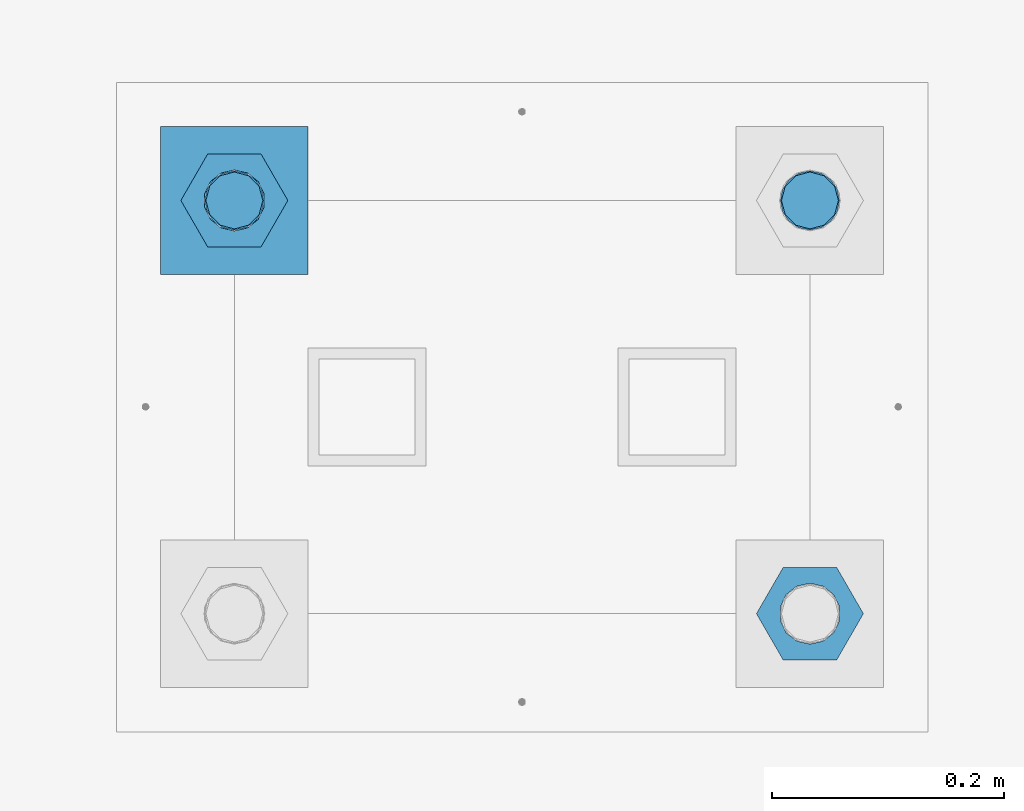
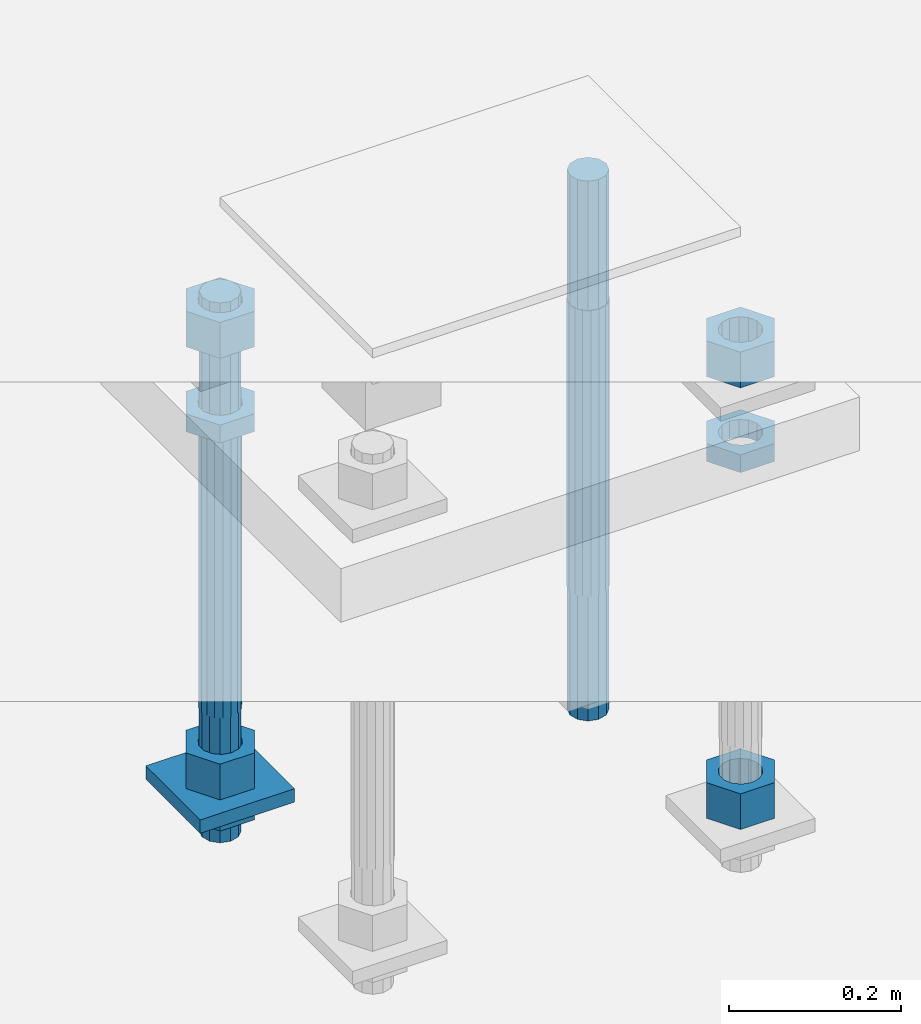
# One storey, part 2574 of 3843: 10 beams, 1 element without a shape of its own.
"""IFC2X3 building model written with IfcOpenShell, lengths in millimetres."""

import ifcopenshell
import ifcopenshell.guid

model = None  # the IFC model being written
_history = None  # IfcOwnerHistory: only IFC2X3 demands one
_inside = {}  # id of a spatial element -> (the spatial element, [elements in it])
_under = {}  # id of a project, library or spatial element -> (it, [spatial elements below it])
_declared = {}  # id of a project -> (the project, [libraries it declares])
_typed = {}  # id of a type object -> (the type object, [elements of that type])
_made_of = {}  # id of a material, layer set ... -> (it, [elements and type objects made of it])


def new_model(schema):
    """Start an empty IFC model of exactly this schema.

    Asked for "IFC4X3", IfcOpenShell would pick the latest addendum, in which some entities
    have other attributes; the version numbers below select the first issue.
    IFC2X3 requires an IfcOwnerHistory on every rooted entity: one is made here for all.
    """
    global model, _history
    if schema == "IFC4X3":
        model = ifcopenshell.file(schema_version=(4, 3, 0, 0))
    else:
        model = ifcopenshell.file(schema=schema)
    _inside.clear()
    _under.clear()
    _declared.clear()
    _typed.clear()
    _made_of.clear()
    _history = None
    if model.schema == "IFC2X3":
        org = make("IfcOrganization", Name="unknown")
        user = make(
            "IfcPersonAndOrganization",
            ThePerson=make("IfcPerson", FamilyName="unknown"),
            TheOrganization=org,
        )
        app = make(
            "IfcApplication",
            ApplicationDeveloper=org,
            Version="unknown",
            ApplicationFullName="unknown",
            ApplicationIdentifier="unknown",
        )
        _history = make(
            "IfcOwnerHistory",
            OwningUser=user,
            OwningApplication=app,
            ChangeAction="ADDED",
            CreationDate=0,
        )
    return model


def make(cls, **values):
    """One entity of the class cls with the attributes given. An attribute that is None is left unset."""
    return model.create_entity(
        cls, **{name: value for name, value in values.items() if value is not None}
    )


def rooted(cls, **values):
    """An entity with a GlobalId (a new one), such as an element, a storey or a relation."""
    return make(cls, GlobalId=ifcopenshell.guid.new(), OwnerHistory=_history, **values)


def si_unit(unit_type, name, prefix=None):
    """IfcSIUnit, for example si_unit("LENGTHUNIT", "METRE", prefix="MILLI")."""
    return make("IfcSIUnit", UnitType=unit_type, Prefix=prefix, Name=name)


def assignment(units):
    """IfcUnitAssignment: the units of a project."""
    return None if units is None else make("IfcUnitAssignment", Units=units)


def point(xyz):
    """IfcCartesianPoint."""
    return None if xyz is None else make("IfcCartesianPoint", Coordinates=xyz)


def direction(xyz):
    """IfcDirection."""
    return None if xyz is None else make("IfcDirection", DirectionRatios=xyz)


def frame(location, z_axis=None, x_axis=None):
    """IfcAxis2Placement3D, a coordinate frame: its origin and axes. An axis left out is left unset."""
    return make(
        "IfcAxis2Placement3D",
        Location=point(location),
        Axis=direction(z_axis),
        RefDirection=direction(x_axis),
    )


def origin_with_axes():
    """The frame at (0, 0, 0) with the z axis (0, 0, 1) and the x axis (1, 0, 0) written out."""
    return frame((0.0, 0.0, 0.0), z_axis=(0.0, 0.0, 1.0), x_axis=(1.0, 0.0, 0.0))


def place(relative_to, where):
    """IfcLocalPlacement: puts the frame where relative to a parent placement (None: the world)."""
    return make(
        "IfcLocalPlacement", PlacementRelTo=relative_to, RelativePlacement=where
    )


def context(
    kind, dimensions, precision=None, world=None, true_north=None, identifier=None
):
    """IfcGeometricRepresentationContext, for example the 3D "Model" context."""
    return make(
        "IfcGeometricRepresentationContext",
        ContextIdentifier=identifier,
        ContextType=kind,
        CoordinateSpaceDimension=dimensions,
        Precision=precision,
        WorldCoordinateSystem=world,
        TrueNorth=true_north,
    )


def subcontext(parent, identifier, kind, view, scale=None):
    """IfcGeometricRepresentationSubContext, for example "Body" below "Model"."""
    return make(
        "IfcGeometricRepresentationSubContext",
        ContextIdentifier=identifier,
        ContextType=kind,
        ParentContext=parent,
        TargetScale=scale,
        TargetView=view,
    )


def project(units=None, contexts=None):
    """IfcProject with its units and contexts."""
    return rooted(
        "IfcProject",
        Name="project",
        RepresentationContexts=contexts,
        UnitsInContext=assignment(units),
    )


def spatial(cls, under=None, at=None, **own):
    """A site, building, storey or space (cls), placed at a placement, below another one or the project."""
    s = rooted(cls, ObjectPlacement=at, **own)
    if under is not None:
        _under.setdefault(under.id(), (under, []))[1].append(s)
    return s


def faces_of(points, faces, orient=None, outer=None):
    """IfcFace entities. A face is a list of loops; a loop is a list of indices into points, from 0.

    orient and outer hold one flag for each loop. By default every Orientation is true, the
    first loop of a face is its IfcFaceOuterBound and the others are IfcFaceBound.
    """
    made = []
    for i, loops in enumerate(faces):
        bounds = []
        for j, loop in enumerate(loops):
            is_outer = j == 0 if outer is None else outer[i][j]
            bounds.append(
                make(
                    "IfcFaceOuterBound" if is_outer else "IfcFaceBound",
                    Bound=make("IfcPolyLoop", Polygon=[points[k] for k in loop]),
                    Orientation=True if orient is None else orient[i][j],
                )
            )
        made.append(make("IfcFace", Bounds=bounds))
    return made


def faceted_brep(points, faces, orient=None, outer=None, voids=None):
    """IfcFacetedBrep: a solid bounded by flat faces; with voids (closed shells), ...WithVoids."""
    shared = [point(p) for p in points]
    hull = make("IfcClosedShell", CfsFaces=faces_of(shared, faces, orient, outer))
    if voids is None:
        return make("IfcFacetedBrep", Outer=hull)
    return make(
        "IfcFacetedBrepWithVoids",
        Outer=hull,
        Voids=[
            make(cls, CfsFaces=faces_of(shared, fs, o, b)) for cls, fs, o, b in voids
        ],
    )


def shape(context_of_items, identifier, shape_type, items):
    """IfcShapeRepresentation: the items that make up one representation, for example the "Body"."""
    return make(
        "IfcShapeRepresentation",
        ContextOfItems=context_of_items,
        RepresentationIdentifier=identifier,
        RepresentationType=shape_type,
        Items=items,
    )


def material(Name=None, Category=None):
    """IfcMaterial."""
    return make("IfcMaterial", Name=Name, Category=Category)


def made_of(thing, what):
    """Note that an element or type object is made of a material, layer set ...; save() writes the relation."""
    if what is not None:
        _made_of.setdefault(what.id(), (what, []))[1].append(thing)
    return thing


def type_object(cls, material=None, **own):
    """A type object (cls), such as IfcWallType, which elements share."""
    return made_of(rooted(cls, **own), material)


def element(
    cls,
    number,
    at=None,
    inside=None,
    cuts=None,
    type_object=None,
    material=None,
    context=None,
    identifier="Body",
    shape_type=None,
    held_by="IfcProductDefinitionShape",
    body=None,
    shapes=None,
    **own,
):
    """One element of the class cls, such as IfcWall. Its Tag is "e" and its number.

    at: its placement. inside: the storey or other place that contains it. cuts: it is an
    opening in that element (IfcRelVoidsElement). A single representation is given by context,
    identifier, shape_type and body (its items); several are given by shapes. held_by: the class
    of the entity that holds the representations. save() writes the other relations.
    """
    e = rooted(cls, Tag="e%d" % number, ObjectPlacement=at, **own)
    if body is not None:
        shapes = [shape(context, identifier, shape_type, body)]
    if shapes is not None:
        e.Representation = make(held_by, Representations=shapes)
    if inside is not None:
        _inside.setdefault(inside.id(), (inside, []))[1].append(e)
    if cuts is not None:
        rooted(
            "IfcRelVoidsElement", RelatingBuildingElement=cuts, RelatedOpeningElement=e
        )
    if type_object is not None:
        _typed.setdefault(type_object.id(), (type_object, []))[1].append(e)
    return made_of(e, material)


def aggregate(whole, parts):
    """IfcRelAggregates: a whole, such as a stair, and the parts it consists of."""
    return rooted("IfcRelAggregates", RelatingObject=whole, RelatedObjects=parts)


def save(model, path):
    """Write the relations noted so far, then the file.

    IfcRelAggregates (storeys below a building ...), IfcRelContainedInSpatialStructure (elements
    in a storey), IfcRelDefinesByType, IfcRelAssociatesMaterial and IfcRelDeclares: one each for
    every whole, place, type object, material and project.
    """
    for whole, parts in _under.values():
        aggregate(whole, parts)
    for where, things in _inside.values():
        rooted(
            "IfcRelContainedInSpatialStructure",
            RelatedElements=things,
            RelatingStructure=where,
        )
    for kind, things in _typed.values():
        rooted("IfcRelDefinesByType", RelatedObjects=things, RelatingType=kind)
    for what, things in _made_of.values():
        rooted("IfcRelAssociatesMaterial", RelatedObjects=things, RelatingMaterial=what)
    for by, libraries in _declared.values():
        rooted("IfcRelDeclares", RelatingContext=by, RelatedDefinitions=libraries)
    model.write(path)


model = new_model("IFC2X3")

# Units and contexts
model_context = context("Model", 3, precision=1e-05, world=origin_with_axes())
body_context = subcontext(model_context, "Body", "Model", "MODEL_VIEW")
ifc_project = project(units=[si_unit("LENGTHUNIT", "METRE", prefix="MILLI"), si_unit("AREAUNIT", "SQUARE_METRE"), si_unit("VOLUMEUNIT", "CUBIC_METRE"), si_unit("MASSUNIT", "GRAM", prefix="KILO"), si_unit("TIMEUNIT", "SECOND"), si_unit("PLANEANGLEUNIT", "RADIAN"), si_unit("SOLIDANGLEUNIT", "STERADIAN"), si_unit("THERMODYNAMICTEMPERATUREUNIT", "DEGREE_CELSIUS"), si_unit("LUMINOUSINTENSITYUNIT", "LUMEN")], contexts=[model_context])

# Site, building, storey
site_placement = place(None, origin_with_axes())
site = spatial("IfcSite", under=ifc_project, at=site_placement, CompositionType="ELEMENT")
building_placement = place(site_placement, origin_with_axes())
building = spatial("IfcBuilding", under=site, at=building_placement, Name="Undefined", CompositionType="ELEMENT")
storey_placement = place(building_placement, origin_with_axes())
storey = spatial("IfcBuildingStorey", under=building, at=storey_placement, Name="Undefined", CompositionType="ELEMENT", Elevation=0.0)

# Assembly, beams
assembly_placement = place(storey_placement, origin_with_axes())
assembly = element("IfcElementAssembly", 1, at=assembly_placement, inside=storey, Name="TEMPLATE", AssemblyPlace="NOTDEFINED", PredefinedType="RIGID_FRAME")
ifc_material_1 = material(Name="STEEL/A572-50")
beam_type_1 = type_object("IfcBeamType", PredefinedType="NOTDEFINED")
beam_1_placement = place(assembly_placement, frame((104908.35, 10642.5999984741, 29244.925), z_axis=(-1.0, 0.0, 0.0), x_axis=(0.0, -1.0, 0.0)))
beam_1 = element("IfcBeam", 2, at=beam_1_placement, type_object=beam_type_1, material=ifc_material_1, Name="WASHER_PLATE", context=body_context, shape_type="Brep", body=[
    faceted_brep([(0.0, 9.52500000000146, -63.5), (0.0, 9.52500000000146, 63.5), (127.0, 9.52500000000146, 63.5), (127.0, 9.52500000000146, -63.5), (0.0, -9.52500000000146, 63.5), (127.0, -9.52500000000146, 63.5), (0.0, -9.52500000000146, -63.5), (127.0, -9.52500000000146, -63.5)], [[[0, 1, 2, 3]], [[1, 4, 5, 2]], [[4, 6, 7, 5]], [[6, 0, 3, 7]], [[5, 7, 3, 2]], [[6, 4, 1, 0]]]),
])
ifc_material_2 = material(Name="STEEL/A36")
beam_type_2 = type_object("IfcBeamType", Name="2_HALF_NUT", PredefinedType="NOTDEFINED")
beam_2_placement = place(assembly_placement, frame((104908.35, 10579.0999984741, 29787.85), z_axis=(0.0, -1.0, 0.0), x_axis=(0.0, 0.0, -1.0)))
beam_2 = element("IfcBeam", 3, at=beam_2_placement, type_object=beam_type_2, material=ifc_material_2, Name="NUT", ObjectType="2_HALF_NUT", context=body_context, shape_type="Brep", body=[
    faceted_brep([(0.0, -46.0369987487793, 0.0), (0.0, -23.0184993743896, -39.869213104248), (25.4000000000015, -23.0184993743896, -39.869213104248), (25.4000000000015, -46.0369987487793, 0.0), (0.0, 23.0184993743896, -39.869213104248), (25.4000000000015, 23.0184993743896, -39.869213104248), (0.0, 46.0369987487793, 0.0), (25.4000000000015, 46.0369987487793, 0.0), (0.0, 23.0184993743896, 39.869213104248), (25.4000000000015, 23.0184993743896, 39.869213104248), (0.0, -23.0184993743896, 39.869213104248), (25.4000000000015, -23.0184993743896, 39.869213104248), (0.0, 0.0, 26.1940002441406), (0.0, 11.3650617044477, 23.5999013092805), (25.4000000000015, 11.3650617044477, 23.5999013092805), (25.4000000000015, 0.0, 26.1940002441406), (0.0, 20.4791109456419, 16.3316083006721), (25.4000000000015, 20.4791109456419, 16.3316083006721), (0.0, 25.5370200498292, 5.82867859874386), (25.4000000000015, 25.5370200498292, 5.82867859874386), (0.0, 25.5370200498292, -5.82867859874386), (25.4000000000015, 25.5370200498292, -5.82867859874386), (0.0, 20.4791109456419, -16.3316083006721), (25.4000000000015, 20.4791109456419, -16.3316083006721), (0.0, 11.3650617044477, -23.5999013092805), (25.4000000000015, 11.3650617044477, -23.5999013092805), (0.0, 0.0, -26.1940002441406), (25.4000000000015, 0.0, -26.1940002441406), (0.0, -11.3650617044477, -23.5999013092805), (25.4000000000015, -11.3650617044477, -23.5999013092805), (0.0, -20.4791109456419, -16.3316083006721), (25.4000000000015, -20.4791109456419, -16.3316083006721), (0.0, -25.5370200498292, -5.82867859874386), (25.4000000000015, -25.5370200498292, -5.82867859874386), (0.0, -25.5370200498292, 5.82867859874386), (25.4000000000015, -25.5370200498292, 5.82867859874386), (0.0, -20.4791109456419, 16.3316083006721), (25.4000000000015, -20.4791109456419, 16.3316083006721), (0.0, -11.3650617044477, 23.5999013092805), (25.4000000000015, -11.3650617044477, 23.5999013092805)], [[[0, 1, 2, 3]], [[1, 4, 5, 2]], [[4, 6, 7, 5]], [[6, 8, 9, 7]], [[8, 10, 11, 9]], [[10, 0, 3, 11]], [[12, 13, 14, 15]], [[13, 16, 17, 14]], [[16, 18, 19, 17]], [[18, 20, 21, 19]], [[20, 22, 23, 21]], [[22, 24, 25, 23]], [[24, 26, 27, 25]], [[26, 28, 29, 27]], [[28, 30, 31, 29]], [[30, 32, 33, 31]], [[32, 34, 35, 33]], [[34, 36, 37, 35]], [[36, 38, 39, 37]], [[38, 12, 15, 39]], [[5, 7, 9, 11, 3, 2], [17, 19, 21, 23, 25, 27, 29, 31, 33, 35, 37, 39, 15, 14]], [[10, 8, 6, 4, 1, 0], [38, 36, 34, 32, 30, 28, 26, 24, 22, 20, 18, 16, 13, 12]]]),
])
beam_3_placement = place(assembly_placement, frame((104908.35, 10579.0999984741, 29235.4), z_axis=(0.0, -1.0, 0.0), x_axis=(0.0, 0.0, -1.0)))
beam_3 = element("IfcBeam", 4, at=beam_3_placement, type_object=beam_type_2, material=ifc_material_2, Name="NUT", ObjectType="2_HALF_NUT", context=body_context, shape_type="Brep", body=[
    faceted_brep([(0.0, -46.0369987487793, 0.0), (0.0, -23.0184993743896, -39.869213104248), (25.4000000000015, -23.0184993743896, -39.869213104248), (25.4000000000015, -46.0369987487793, 0.0), (0.0, 23.0184993743896, -39.869213104248), (25.4000000000015, 23.0184993743896, -39.869213104248), (0.0, 46.0369987487793, 0.0), (25.4000000000015, 46.0369987487793, 0.0), (0.0, 23.0184993743896, 39.869213104248), (25.4000000000015, 23.0184993743896, 39.869213104248), (0.0, -23.0184993743896, 39.869213104248), (25.4000000000015, -23.0184993743896, 39.869213104248), (0.0, 0.0, 26.1940002441406), (0.0, 11.3650617044477, 23.5999013092805), (25.4000000000015, 11.3650617044477, 23.5999013092805), (25.4000000000015, 0.0, 26.1940002441406), (0.0, 20.4791109456419, 16.3316083006721), (25.4000000000015, 20.4791109456419, 16.3316083006721), (0.0, 25.5370200498292, 5.82867859874386), (25.4000000000015, 25.5370200498292, 5.82867859874386), (0.0, 25.5370200498292, -5.82867859874386), (25.4000000000015, 25.5370200498292, -5.82867859874386), (0.0, 20.4791109456419, -16.3316083006721), (25.4000000000015, 20.4791109456419, -16.3316083006721), (0.0, 11.3650617044477, -23.5999013092805), (25.4000000000015, 11.3650617044477, -23.5999013092805), (0.0, 0.0, -26.1940002441406), (25.4000000000015, 0.0, -26.1940002441406), (0.0, -11.3650617044477, -23.5999013092805), (25.4000000000015, -11.3650617044477, -23.5999013092805), (0.0, -20.4791109456419, -16.3316083006721), (25.4000000000015, -20.4791109456419, -16.3316083006721), (0.0, -25.5370200498292, -5.82867859874386), (25.4000000000015, -25.5370200498292, -5.82867859874386), (0.0, -25.5370200498292, 5.82867859874386), (25.4000000000015, -25.5370200498292, 5.82867859874386), (0.0, -20.4791109456419, 16.3316083006721), (25.4000000000015, -20.4791109456419, 16.3316083006721), (0.0, -11.3650617044477, 23.5999013092805), (25.4000000000015, -11.3650617044477, 23.5999013092805)], [[[0, 1, 2, 3]], [[1, 4, 5, 2]], [[4, 6, 7, 5]], [[6, 8, 9, 7]], [[8, 10, 11, 9]], [[10, 0, 3, 11]], [[12, 13, 14, 15]], [[13, 16, 17, 14]], [[16, 18, 19, 17]], [[18, 20, 21, 19]], [[20, 22, 23, 21]], [[22, 24, 25, 23]], [[24, 26, 27, 25]], [[26, 28, 29, 27]], [[28, 30, 31, 29]], [[30, 32, 33, 31]], [[32, 34, 35, 33]], [[34, 36, 37, 35]], [[36, 38, 39, 37]], [[38, 12, 15, 39]], [[5, 7, 9, 11, 3, 2], [17, 19, 21, 23, 25, 27, 29, 31, 33, 35, 37, 39, 15, 14]], [[10, 8, 6, 4, 1, 0], [38, 36, 34, 32, 30, 28, 26, 24, 22, 20, 18, 16, 13, 12]]]),
])
beam_4_placement = place(assembly_placement, frame((105403.65, 10223.4999984741, 29787.85), z_axis=(0.0, -1.0, 0.0), x_axis=(0.0, 0.0, -1.0)))
beam_4 = element("IfcBeam", 5, at=beam_4_placement, type_object=beam_type_2, material=ifc_material_2, Name="NUT", ObjectType="2_HALF_NUT", context=body_context, shape_type="Brep", body=[
    faceted_brep([(0.0, -46.0369987487793, 0.0), (0.0, -23.0184993743896, -39.869213104248), (25.4000000000015, -23.0184993743896, -39.869213104248), (25.4000000000015, -46.0369987487793, 0.0), (0.0, 23.0184993743896, -39.869213104248), (25.4000000000015, 23.0184993743896, -39.869213104248), (0.0, 46.0369987487793, 0.0), (25.4000000000015, 46.0369987487793, 0.0), (0.0, 23.0184993743896, 39.869213104248), (25.4000000000015, 23.0184993743896, 39.869213104248), (0.0, -23.0184993743896, 39.869213104248), (25.4000000000015, -23.0184993743896, 39.869213104248), (0.0, 0.0, 26.1940002441406), (0.0, 11.3650617044477, 23.5999013092805), (25.4000000000015, 11.3650617044477, 23.5999013092805), (25.4000000000015, 0.0, 26.1940002441406), (0.0, 20.4791109456419, 16.3316083006721), (25.4000000000015, 20.4791109456419, 16.3316083006721), (0.0, 25.5370200498292, 5.82867859874386), (25.4000000000015, 25.5370200498292, 5.82867859874386), (0.0, 25.5370200498292, -5.82867859874386), (25.4000000000015, 25.5370200498292, -5.82867859874386), (0.0, 20.4791109456419, -16.3316083006721), (25.4000000000015, 20.4791109456419, -16.3316083006721), (0.0, 11.3650617044477, -23.5999013092805), (25.4000000000015, 11.3650617044477, -23.5999013092805), (0.0, 0.0, -26.1940002441406), (25.4000000000015, 0.0, -26.1940002441406), (0.0, -11.3650617044477, -23.5999013092805), (25.4000000000015, -11.3650617044477, -23.5999013092805), (0.0, -20.4791109456419, -16.3316083006721), (25.4000000000015, -20.4791109456419, -16.3316083006721), (0.0, -25.5370200498292, -5.82867859874386), (25.4000000000015, -25.5370200498292, -5.82867859874386), (0.0, -25.5370200498292, 5.82867859874386), (25.4000000000015, -25.5370200498292, 5.82867859874386), (0.0, -20.4791109456419, 16.3316083006721), (25.4000000000015, -20.4791109456419, 16.3316083006721), (0.0, -11.3650617044477, 23.5999013092805), (25.4000000000015, -11.3650617044477, 23.5999013092805)], [[[0, 1, 2, 3]], [[1, 4, 5, 2]], [[4, 6, 7, 5]], [[6, 8, 9, 7]], [[8, 10, 11, 9]], [[10, 0, 3, 11]], [[12, 13, 14, 15]], [[13, 16, 17, 14]], [[16, 18, 19, 17]], [[18, 20, 21, 19]], [[20, 22, 23, 21]], [[22, 24, 25, 23]], [[24, 26, 27, 25]], [[26, 28, 29, 27]], [[28, 30, 31, 29]], [[30, 32, 33, 31]], [[32, 34, 35, 33]], [[34, 36, 37, 35]], [[36, 38, 39, 37]], [[38, 12, 15, 39]], [[5, 7, 9, 11, 3, 2], [17, 19, 21, 23, 25, 27, 29, 31, 33, 35, 37, 39, 15, 14]], [[10, 8, 6, 4, 1, 0], [38, 36, 34, 32, 30, 28, 26, 24, 22, 20, 18, 16, 13, 12]]]),
])
beam_type_3 = type_object("IfcBeamType", Name="2_HEAVY_HEX_NUT", PredefinedType="NOTDEFINED")
beam_5_placement = place(assembly_placement, frame((104908.35, 10579.0999984741, 29933.9), z_axis=(0.0, -1.0, 0.0), x_axis=(0.0, 0.0, -1.0)))
beam_5 = element("IfcBeam", 6, at=beam_5_placement, type_object=beam_type_3, material=ifc_material_2, Name="NUT", ObjectType="2_HEAVY_HEX_NUT", context=body_context, shape_type="Brep", body=[
    faceted_brep([(0.0, -46.0369987487793, 0.0), (0.0, -23.0184993743896, -39.869213104248), (50.7999999999993, -23.0184993743896, -39.869213104248), (50.7999999999993, -46.0369987487793, 0.0), (0.0, 23.0184993743896, -39.869213104248), (50.7999999999993, 23.0184993743896, -39.869213104248), (0.0, 46.0369987487793, 0.0), (50.7999999999993, 46.0369987487793, 0.0), (0.0, 23.0184993743896, 39.869213104248), (50.7999999999993, 23.0184993743896, 39.869213104248), (0.0, -23.0184993743896, 39.869213104248), (50.7999999999993, -23.0184993743896, 39.869213104248), (0.0, 0.0, 26.1940002441406), (0.0, 11.3650617044477, 23.5999013092805), (50.7999999999993, 11.3650617044477, 23.5999013092805), (50.7999999999993, 0.0, 26.1940002441406), (0.0, 20.4791109456419, 16.3316083006721), (50.7999999999993, 20.4791109456419, 16.3316083006721), (0.0, 25.5370200498292, 5.82867859874386), (50.7999999999993, 25.5370200498292, 5.82867859874386), (0.0, 25.5370200498292, -5.82867859874386), (50.7999999999993, 25.5370200498292, -5.82867859874386), (0.0, 20.4791109456419, -16.3316083006721), (50.7999999999993, 20.4791109456419, -16.3316083006721), (0.0, 11.3650617044477, -23.5999013092805), (50.7999999999993, 11.3650617044477, -23.5999013092805), (0.0, 0.0, -26.1940002441406), (50.7999999999993, 0.0, -26.1940002441406), (0.0, -11.3650617044477, -23.5999013092805), (50.7999999999993, -11.3650617044477, -23.5999013092805), (0.0, -20.4791109456419, -16.3316083006721), (50.7999999999993, -20.4791109456419, -16.3316083006721), (0.0, -25.5370200498292, -5.82867859874386), (50.7999999999993, -25.5370200498292, -5.82867859874386), (0.0, -25.5370200498292, 5.82867859874386), (50.7999999999993, -25.5370200498292, 5.82867859874386), (0.0, -20.4791109456419, 16.3316083006721), (50.7999999999993, -20.4791109456419, 16.3316083006721), (0.0, -11.3650617044477, 23.5999013092805), (50.7999999999993, -11.3650617044477, 23.5999013092805)], [[[0, 1, 2, 3]], [[1, 4, 5, 2]], [[4, 6, 7, 5]], [[6, 8, 9, 7]], [[8, 10, 11, 9]], [[10, 0, 3, 11]], [[12, 13, 14, 15]], [[13, 16, 17, 14]], [[16, 18, 19, 17]], [[18, 20, 21, 19]], [[20, 22, 23, 21]], [[22, 24, 25, 23]], [[24, 26, 27, 25]], [[26, 28, 29, 27]], [[28, 30, 31, 29]], [[30, 32, 33, 31]], [[32, 34, 35, 33]], [[34, 36, 37, 35]], [[36, 38, 39, 37]], [[38, 12, 15, 39]], [[5, 7, 9, 11, 3, 2], [17, 19, 21, 23, 25, 27, 29, 31, 33, 35, 37, 39, 15, 14]], [[10, 8, 6, 4, 1, 0], [38, 36, 34, 32, 30, 28, 26, 24, 22, 20, 18, 16, 13, 12]]]),
])
beam_6_placement = place(assembly_placement, frame((104908.35, 10579.0999984741, 29305.25), z_axis=(0.0, -1.0, 0.0), x_axis=(0.0, 0.0, -1.0)))
beam_6 = element("IfcBeam", 7, at=beam_6_placement, type_object=beam_type_3, material=ifc_material_2, Name="NUT", ObjectType="2_HEAVY_HEX_NUT", context=body_context, shape_type="Brep", body=[
    faceted_brep([(0.0, -46.0369987487793, 0.0), (0.0, -23.0184993743896, -39.869213104248), (50.7999999999993, -23.0184993743896, -39.869213104248), (50.7999999999993, -46.0369987487793, 0.0), (0.0, 23.0184993743896, -39.869213104248), (50.7999999999993, 23.0184993743896, -39.869213104248), (0.0, 46.0369987487793, 0.0), (50.7999999999993, 46.0369987487793, 0.0), (0.0, 23.0184993743896, 39.869213104248), (50.7999999999993, 23.0184993743896, 39.869213104248), (0.0, -23.0184993743896, 39.869213104248), (50.7999999999993, -23.0184993743896, 39.869213104248), (0.0, 0.0, 26.1940002441406), (0.0, 11.3650617044477, 23.5999013092805), (50.7999999999993, 11.3650617044477, 23.5999013092805), (50.7999999999993, 0.0, 26.1940002441406), (0.0, 20.4791109456419, 16.3316083006721), (50.7999999999993, 20.4791109456419, 16.3316083006721), (0.0, 25.5370200498292, 5.82867859874386), (50.7999999999993, 25.5370200498292, 5.82867859874386), (0.0, 25.5370200498292, -5.82867859874386), (50.7999999999993, 25.5370200498292, -5.82867859874386), (0.0, 20.4791109456419, -16.3316083006721), (50.7999999999993, 20.4791109456419, -16.3316083006721), (0.0, 11.3650617044477, -23.5999013092805), (50.7999999999993, 11.3650617044477, -23.5999013092805), (0.0, 0.0, -26.1940002441406), (50.7999999999993, 0.0, -26.1940002441406), (0.0, -11.3650617044477, -23.5999013092805), (50.7999999999993, -11.3650617044477, -23.5999013092805), (0.0, -20.4791109456419, -16.3316083006721), (50.7999999999993, -20.4791109456419, -16.3316083006721), (0.0, -25.5370200498292, -5.82867859874386), (50.7999999999993, -25.5370200498292, -5.82867859874386), (0.0, -25.5370200498292, 5.82867859874386), (50.7999999999993, -25.5370200498292, 5.82867859874386), (0.0, -20.4791109456419, 16.3316083006721), (50.7999999999993, -20.4791109456419, 16.3316083006721), (0.0, -11.3650617044477, 23.5999013092805), (50.7999999999993, -11.3650617044477, 23.5999013092805)], [[[0, 1, 2, 3]], [[1, 4, 5, 2]], [[4, 6, 7, 5]], [[6, 8, 9, 7]], [[8, 10, 11, 9]], [[10, 0, 3, 11]], [[12, 13, 14, 15]], [[13, 16, 17, 14]], [[16, 18, 19, 17]], [[18, 20, 21, 19]], [[20, 22, 23, 21]], [[22, 24, 25, 23]], [[24, 26, 27, 25]], [[26, 28, 29, 27]], [[28, 30, 31, 29]], [[30, 32, 33, 31]], [[32, 34, 35, 33]], [[34, 36, 37, 35]], [[36, 38, 39, 37]], [[38, 12, 15, 39]], [[5, 7, 9, 11, 3, 2], [17, 19, 21, 23, 25, 27, 29, 31, 33, 35, 37, 39, 15, 14]], [[10, 8, 6, 4, 1, 0], [38, 36, 34, 32, 30, 28, 26, 24, 22, 20, 18, 16, 13, 12]]]),
])
beam_7_placement = place(assembly_placement, frame((105403.65, 10223.4999984741, 29933.9), z_axis=(0.0, -1.0, 0.0), x_axis=(0.0, 0.0, -1.0)))
beam_7 = element("IfcBeam", 8, at=beam_7_placement, type_object=beam_type_3, material=ifc_material_2, Name="NUT", ObjectType="2_HEAVY_HEX_NUT", context=body_context, shape_type="Brep", body=[
    faceted_brep([(0.0, -46.0369987487793, 0.0), (0.0, -23.0184993743896, -39.869213104248), (50.7999999999993, -23.0184993743896, -39.869213104248), (50.7999999999993, -46.0369987487793, 0.0), (0.0, 23.0184993743896, -39.869213104248), (50.7999999999993, 23.0184993743896, -39.869213104248), (0.0, 46.0369987487793, 0.0), (50.7999999999993, 46.0369987487793, 0.0), (0.0, 23.0184993743896, 39.869213104248), (50.7999999999993, 23.0184993743896, 39.869213104248), (0.0, -23.0184993743896, 39.869213104248), (50.7999999999993, -23.0184993743896, 39.869213104248), (0.0, 0.0, 26.1940002441406), (0.0, 11.3650617044477, 23.5999013092805), (50.7999999999993, 11.3650617044477, 23.5999013092805), (50.7999999999993, 0.0, 26.1940002441406), (0.0, 20.4791109456419, 16.3316083006721), (50.7999999999993, 20.4791109456419, 16.3316083006721), (0.0, 25.5370200498292, 5.82867859874386), (50.7999999999993, 25.5370200498292, 5.82867859874386), (0.0, 25.5370200498292, -5.82867859874386), (50.7999999999993, 25.5370200498292, -5.82867859874386), (0.0, 20.4791109456419, -16.3316083006721), (50.7999999999993, 20.4791109456419, -16.3316083006721), (0.0, 11.3650617044477, -23.5999013092805), (50.7999999999993, 11.3650617044477, -23.5999013092805), (0.0, 0.0, -26.1940002441406), (50.7999999999993, 0.0, -26.1940002441406), (0.0, -11.3650617044477, -23.5999013092805), (50.7999999999993, -11.3650617044477, -23.5999013092805), (0.0, -20.4791109456419, -16.3316083006721), (50.7999999999993, -20.4791109456419, -16.3316083006721), (0.0, -25.5370200498292, -5.82867859874386), (50.7999999999993, -25.5370200498292, -5.82867859874386), (0.0, -25.5370200498292, 5.82867859874386), (50.7999999999993, -25.5370200498292, 5.82867859874386), (0.0, -20.4791109456419, 16.3316083006721), (50.7999999999993, -20.4791109456419, 16.3316083006721), (0.0, -11.3650617044477, 23.5999013092805), (50.7999999999993, -11.3650617044477, 23.5999013092805)], [[[0, 1, 2, 3]], [[1, 4, 5, 2]], [[4, 6, 7, 5]], [[6, 8, 9, 7]], [[8, 10, 11, 9]], [[10, 0, 3, 11]], [[12, 13, 14, 15]], [[13, 16, 17, 14]], [[16, 18, 19, 17]], [[18, 20, 21, 19]], [[20, 22, 23, 21]], [[22, 24, 25, 23]], [[24, 26, 27, 25]], [[26, 28, 29, 27]], [[28, 30, 31, 29]], [[30, 32, 33, 31]], [[32, 34, 35, 33]], [[34, 36, 37, 35]], [[36, 38, 39, 37]], [[38, 12, 15, 39]], [[5, 7, 9, 11, 3, 2], [17, 19, 21, 23, 25, 27, 29, 31, 33, 35, 37, 39, 15, 14]], [[10, 8, 6, 4, 1, 0], [38, 36, 34, 32, 30, 28, 26, 24, 22, 20, 18, 16, 13, 12]]]),
])
beam_8_placement = place(assembly_placement, frame((105403.65, 10223.4999984741, 29305.25), z_axis=(0.0, -1.0, 0.0), x_axis=(0.0, 0.0, -1.0)))
beam_8 = element("IfcBeam", 9, at=beam_8_placement, type_object=beam_type_3, material=ifc_material_2, Name="NUT", ObjectType="2_HEAVY_HEX_NUT", context=body_context, shape_type="Brep", body=[
    faceted_brep([(0.0, -46.0369987487793, 0.0), (0.0, -23.0184993743896, -39.869213104248), (50.7999999999993, -23.0184993743896, -39.869213104248), (50.7999999999993, -46.0369987487793, 0.0), (0.0, 23.0184993743896, -39.869213104248), (50.7999999999993, 23.0184993743896, -39.869213104248), (0.0, 46.0369987487793, 0.0), (50.7999999999993, 46.0369987487793, 0.0), (0.0, 23.0184993743896, 39.869213104248), (50.7999999999993, 23.0184993743896, 39.869213104248), (0.0, -23.0184993743896, 39.869213104248), (50.7999999999993, -23.0184993743896, 39.869213104248), (0.0, 0.0, 26.1940002441406), (0.0, 11.3650617044477, 23.5999013092805), (50.7999999999993, 11.3650617044477, 23.5999013092805), (50.7999999999993, 0.0, 26.1940002441406), (0.0, 20.4791109456419, 16.3316083006721), (50.7999999999993, 20.4791109456419, 16.3316083006721), (0.0, 25.5370200498292, 5.82867859874386), (50.7999999999993, 25.5370200498292, 5.82867859874386), (0.0, 25.5370200498292, -5.82867859874386), (50.7999999999993, 25.5370200498292, -5.82867859874386), (0.0, 20.4791109456419, -16.3316083006721), (50.7999999999993, 20.4791109456419, -16.3316083006721), (0.0, 11.3650617044477, -23.5999013092805), (50.7999999999993, 11.3650617044477, -23.5999013092805), (0.0, 0.0, -26.1940002441406), (50.7999999999993, 0.0, -26.1940002441406), (0.0, -11.3650617044477, -23.5999013092805), (50.7999999999993, -11.3650617044477, -23.5999013092805), (0.0, -20.4791109456419, -16.3316083006721), (50.7999999999993, -20.4791109456419, -16.3316083006721), (0.0, -25.5370200498292, -5.82867859874386), (50.7999999999993, -25.5370200498292, -5.82867859874386), (0.0, -25.5370200498292, 5.82867859874386), (50.7999999999993, -25.5370200498292, 5.82867859874386), (0.0, -20.4791109456419, 16.3316083006721), (50.7999999999993, -20.4791109456419, 16.3316083006721), (0.0, -11.3650617044477, 23.5999013092805), (50.7999999999993, -11.3650617044477, 23.5999013092805)], [[[0, 1, 2, 3]], [[1, 4, 5, 2]], [[4, 6, 7, 5]], [[6, 8, 9, 7]], [[8, 10, 11, 9]], [[10, 0, 3, 11]], [[12, 13, 14, 15]], [[13, 16, 17, 14]], [[16, 18, 19, 17]], [[18, 20, 21, 19]], [[20, 22, 23, 21]], [[22, 24, 25, 23]], [[24, 26, 27, 25]], [[26, 28, 29, 27]], [[28, 30, 31, 29]], [[30, 32, 33, 31]], [[32, 34, 35, 33]], [[34, 36, 37, 35]], [[36, 38, 39, 37]], [[38, 12, 15, 39]], [[5, 7, 9, 11, 3, 2], [17, 19, 21, 23, 25, 27, 29, 31, 33, 35, 37, 39, 15, 14]], [[10, 8, 6, 4, 1, 0], [38, 36, 34, 32, 30, 28, 26, 24, 22, 20, 18, 16, 13, 12]]]),
])
ifc_material_3 = material()
beam_type_4 = type_object("IfcBeamType", PredefinedType="NOTDEFINED")
beam_9_placement = place(assembly_placement, frame((105403.65, 10579.0999984741, 29762.45), z_axis=(0.0, -1.0, 0.0), x_axis=(0.0, 0.0, -1.0)))
beam_9 = element("IfcBeam", 10, at=beam_9_placement, type_object=beam_type_4, material=ifc_material_3, Name="ANCHOR_ROD", context=body_context, shape_type="Brep", body=[
    faceted_brep([(-184.150000000001, -21.217622392709, 12.25), (-184.150000000001, -12.2499999999854, 21.2176223927163), (-184.150000000001, 1.45519152283669e-11, 24.5), (-184.150000000001, 12.2500000000146, 21.2176223927163), (-184.150000000001, 21.2176223927381, 12.25), (-184.150000000001, 24.5000000000146, 0.0), (-184.150000000001, 21.2176223927381, -12.25), (-184.150000000001, 12.2500000000146, -21.2176223927163), (-184.150000000001, 1.45519152283669e-11, -24.5), (-184.150000000001, -12.2499999999854, -21.2176223927163), (-184.150000000001, -21.217622392709, -12.25), (-184.150000000001, -24.4999999999854, 0.0), (0.0, 24.5000000000146, 0.0), (0.0, 21.2176223927381, -12.25), (0.0, 12.2500000000146, -21.2176223927163), (0.0, 1.45519152283669e-11, -24.5), (0.0, -12.2499999999854, -21.2176223927163), (0.0, -21.217622392709, -12.25), (0.0, -24.4999999999854, 0.0), (0.0, -21.217622392709, 12.25), (0.0, -12.2499999999854, 21.2176223927163), (0.0, 1.45519152283669e-11, 24.5), (0.0, 12.2500000000146, 21.2176223927163), (0.0, 21.2176223927381, 12.25), (0.0, -23.4665401257807, 9.72015918207035), (0.0, -17.9605122421344, 17.9605122421417), (0.0, -9.72015918207762, 23.466540125788), (0.0, 0.0, 25.4000000000015), (0.0, 9.72015918207762, 23.466540125788), (0.0, 17.9605122421344, 17.9605122421417), (0.0, 23.4665401257807, 9.72015918207035), (0.0, 25.3999996185303, 0.0), (0.0, 23.4665401257807, -9.72015918207035), (0.0, 17.9605122421344, -17.9605122421417), (0.0, 9.72015918207762, -23.466540125788), (0.0, 0.0, -25.4000000000015), (0.0, -9.72015918207762, -23.466540125788), (0.0, -17.9605122421344, -17.9605122421417), (0.0, -23.4665401257807, -9.72015918207035), (0.0, -25.3999996185303, 0.0), (406.399999999998, -25.3999999999942, 0.0), (406.399999999998, -23.4665401257807, 9.72015918207035), (406.399999999998, -17.9605122421344, 17.9605122421417), (406.399999999998, -9.72015918207762, 23.466540125788), (406.399999999998, 0.0, 25.4000000000015), (406.399999999998, 9.72015918207762, 23.466540125788), (406.399999999998, 17.9605122421344, 17.9605122421417), (406.399999999998, 23.4665401257807, 9.72015918207035), (406.399999999998, 25.3999999999942, 0.0), (406.399999999998, 23.4665401257807, -9.72015918207035), (406.399999999998, 17.9605122421344, -17.9605122421417), (406.399999999998, 9.72015918207762, -23.466540125788), (406.399999999998, 0.0, -25.4000000000015), (406.399999999998, -9.72015918207762, -23.466540125788), (406.399999999998, -17.9605122421344, -17.9605122421417), (406.399999999998, -23.4665401257807, -9.72015918207035), (406.399999999998, -12.2499999999854, 21.2176223927163), (406.399999999998, 1.45519152283669e-11, 24.5), (406.399999999998, 12.2500000000146, 21.2176223927163), (406.399999999998, 21.2176223927381, 12.25), (406.399999999998, 24.5000000000146, 0.0), (406.399999999998, 21.2176223927381, -12.25), (406.399999999998, 12.2500000000146, -21.2176223927163), (406.399999999998, 1.45519152283669e-11, -24.5), (406.399999999998, -12.2499999999854, -21.2176223927163), (406.399999999998, -21.217622392709, -12.25), (406.399999999998, -24.4999999999854, 0.0), (406.399999999998, -21.217622392709, 12.25), (584.200000000001, -12.2499999999854, -21.2176223927163), (584.200000000001, 1.45519152283669e-11, -24.5), (584.200000000001, 12.2500000000146, -21.2176223927163), (584.200000000001, 21.2176223927381, -12.25), (584.200000000001, 24.5000000000146, 0.0), (584.200000000001, 21.2176223927381, 12.25), (584.200000000001, 12.2500000000146, 21.2176223927163), (584.200000000001, 1.45519152283669e-11, 24.5), (584.200000000001, -12.2499999999854, 21.2176223927163), (584.200000000001, -21.217622392709, 12.25), (584.200000000001, -24.4999999999854, 0.0), (584.200000000001, -21.217622392709, -12.25)], [[[0, 1, 2, 3, 4, 5, 6, 7, 8, 9, 10, 11]], [[6, 5, 12, 13]], [[7, 6, 13, 14]], [[8, 7, 14, 15]], [[9, 8, 15, 16]], [[10, 9, 16, 17]], [[11, 10, 17, 18]], [[0, 11, 18, 19]], [[1, 0, 19, 20]], [[2, 1, 20, 21]], [[3, 2, 21, 22]], [[4, 3, 22, 23]], [[5, 4, 23, 12]], [[24, 25, 26, 27, 28, 29, 30, 31, 32, 33, 34, 35, 36, 37, 38, 39], [22, 21, 20, 19, 18, 17, 16, 15, 14, 13, 12, 23]], [[24, 39, 40, 41]], [[25, 24, 41, 42]], [[26, 25, 42, 43]], [[27, 26, 43, 44]], [[28, 27, 44, 45]], [[29, 28, 45, 46]], [[30, 29, 46, 47]], [[31, 30, 47, 48]], [[32, 31, 48, 49]], [[33, 32, 49, 50]], [[34, 33, 50, 51]], [[35, 34, 51, 52]], [[36, 35, 52, 53]], [[37, 36, 53, 54]], [[38, 37, 54, 55]], [[39, 38, 55, 40]], [[54, 53, 52, 51, 50, 49, 48, 47, 46, 45, 44, 43, 42, 41, 40, 55], [56, 57, 58, 59, 60, 61, 62, 63, 64, 65, 66, 67]], [[68, 69, 70, 71, 72, 73, 74, 75, 76, 77, 78, 79]], [[76, 75, 57, 56]], [[77, 76, 56, 67]], [[78, 77, 67, 66]], [[79, 78, 66, 65]], [[68, 79, 65, 64]], [[69, 68, 64, 63]], [[70, 69, 63, 62]], [[71, 70, 62, 61]], [[72, 71, 61, 60]], [[73, 72, 60, 59]], [[74, 73, 59, 58]], [[75, 74, 58, 57]]]),
])
beam_10_placement = place(assembly_placement, frame((104908.35, 10579.0999984741, 29762.45), z_axis=(0.0, -1.0, 0.0), x_axis=(0.0, 0.0, -1.0)))
beam_10 = element("IfcBeam", 11, at=beam_10_placement, type_object=beam_type_4, material=ifc_material_3, Name="ANCHOR_ROD", context=body_context, shape_type="Brep", body=[
    faceted_brep([(-184.150000000001, -21.217622392709, 12.25), (-184.150000000001, -12.2499999999854, 21.2176223927163), (-184.150000000001, 1.45519152283669e-11, 24.5), (-184.150000000001, 12.2500000000146, 21.2176223927163), (-184.150000000001, 21.2176223927381, 12.25), (-184.150000000001, 24.5000000000146, 0.0), (-184.150000000001, 21.2176223927381, -12.25), (-184.150000000001, 12.2500000000146, -21.2176223927163), (-184.150000000001, 1.45519152283669e-11, -24.5), (-184.150000000001, -12.2499999999854, -21.2176223927163), (-184.150000000001, -21.217622392709, -12.25), (-184.150000000001, -24.4999999999854, 0.0), (0.0, 24.5000000000146, 0.0), (0.0, 21.2176223927381, -12.25), (0.0, 12.2500000000146, -21.2176223927163), (0.0, 1.45519152283669e-11, -24.5), (0.0, -12.2499999999854, -21.2176223927163), (0.0, -21.217622392709, -12.25), (0.0, -24.4999999999854, 0.0), (0.0, -21.217622392709, 12.25), (0.0, -12.2499999999854, 21.2176223927163), (0.0, 1.45519152283669e-11, 24.5), (0.0, 12.2500000000146, 21.2176223927163), (0.0, 21.2176223927381, 12.25), (0.0, -23.4665401257807, 9.72015918207035), (0.0, -17.9605122421344, 17.9605122421417), (0.0, -9.72015918207762, 23.466540125788), (0.0, 0.0, 25.4000000000015), (0.0, 9.72015918207762, 23.466540125788), (0.0, 17.9605122421344, 17.9605122421417), (0.0, 23.4665401257807, 9.72015918207035), (0.0, 25.3999996185303, 0.0), (0.0, 23.4665401257807, -9.72015918207035), (0.0, 17.9605122421344, -17.9605122421417), (0.0, 9.72015918207762, -23.466540125788), (0.0, 0.0, -25.4000000000015), (0.0, -9.72015918207762, -23.466540125788), (0.0, -17.9605122421344, -17.9605122421417), (0.0, -23.4665401257807, -9.72015918207035), (0.0, -25.3999996185303, 0.0), (406.399999999998, -25.3999999999942, 0.0), (406.399999999998, -23.4665401257807, 9.72015918207035), (406.399999999998, -17.9605122421344, 17.9605122421417), (406.399999999998, -9.72015918207762, 23.466540125788), (406.399999999998, 0.0, 25.4000000000015), (406.399999999998, 9.72015918207762, 23.466540125788), (406.399999999998, 17.9605122421344, 17.9605122421417), (406.399999999998, 23.4665401257807, 9.72015918207035), (406.399999999998, 25.3999999999942, 0.0), (406.399999999998, 23.4665401257807, -9.72015918207035), (406.399999999998, 17.9605122421344, -17.9605122421417), (406.399999999998, 9.72015918207762, -23.466540125788), (406.399999999998, 0.0, -25.4000000000015), (406.399999999998, -9.72015918207762, -23.466540125788), (406.399999999998, -17.9605122421344, -17.9605122421417), (406.399999999998, -23.4665401257807, -9.72015918207035), (406.399999999998, -12.2499999999854, 21.2176223927163), (406.399999999998, 1.45519152283669e-11, 24.5), (406.399999999998, 12.2500000000146, 21.2176223927163), (406.399999999998, 21.2176223927381, 12.25), (406.399999999998, 24.5000000000146, 0.0), (406.399999999998, 21.2176223927381, -12.25), (406.399999999998, 12.2500000000146, -21.2176223927163), (406.399999999998, 1.45519152283669e-11, -24.5), (406.399999999998, -12.2499999999854, -21.2176223927163), (406.399999999998, -21.217622392709, -12.25), (406.399999999998, -24.4999999999854, 0.0), (406.399999999998, -21.217622392709, 12.25), (584.200000000001, -12.2499999999854, -21.2176223927163), (584.200000000001, 1.45519152283669e-11, -24.5), (584.200000000001, 12.2500000000146, -21.2176223927163), (584.200000000001, 21.2176223927381, -12.25), (584.200000000001, 24.5000000000146, 0.0), (584.200000000001, 21.2176223927381, 12.25), (584.200000000001, 12.2500000000146, 21.2176223927163), (584.200000000001, 1.45519152283669e-11, 24.5), (584.200000000001, -12.2499999999854, 21.2176223927163), (584.200000000001, -21.217622392709, 12.25), (584.200000000001, -24.4999999999854, 0.0), (584.200000000001, -21.217622392709, -12.25)], [[[0, 1, 2, 3, 4, 5, 6, 7, 8, 9, 10, 11]], [[6, 5, 12, 13]], [[7, 6, 13, 14]], [[8, 7, 14, 15]], [[9, 8, 15, 16]], [[10, 9, 16, 17]], [[11, 10, 17, 18]], [[0, 11, 18, 19]], [[1, 0, 19, 20]], [[2, 1, 20, 21]], [[3, 2, 21, 22]], [[4, 3, 22, 23]], [[5, 4, 23, 12]], [[24, 25, 26, 27, 28, 29, 30, 31, 32, 33, 34, 35, 36, 37, 38, 39], [22, 21, 20, 19, 18, 17, 16, 15, 14, 13, 12, 23]], [[24, 39, 40, 41]], [[25, 24, 41, 42]], [[26, 25, 42, 43]], [[27, 26, 43, 44]], [[28, 27, 44, 45]], [[29, 28, 45, 46]], [[30, 29, 46, 47]], [[31, 30, 47, 48]], [[32, 31, 48, 49]], [[33, 32, 49, 50]], [[34, 33, 50, 51]], [[35, 34, 51, 52]], [[36, 35, 52, 53]], [[37, 36, 53, 54]], [[38, 37, 54, 55]], [[39, 38, 55, 40]], [[54, 53, 52, 51, 50, 49, 48, 47, 46, 45, 44, 43, 42, 41, 40, 55], [56, 57, 58, 59, 60, 61, 62, 63, 64, 65, 66, 67]], [[68, 69, 70, 71, 72, 73, 74, 75, 76, 77, 78, 79]], [[76, 75, 57, 56]], [[77, 76, 56, 67]], [[78, 77, 67, 66]], [[79, 78, 66, 65]], [[68, 79, 65, 64]], [[69, 68, 64, 63]], [[70, 69, 63, 62]], [[71, 70, 62, 61]], [[72, 71, 61, 60]], [[73, 72, 60, 59]], [[74, 73, 59, 58]], [[75, 74, 58, 57]]]),
])
aggregate(assembly, [beam_9, beam_2, beam_5, beam_6, beam_3, beam_1, beam_10, beam_4, beam_7, beam_8])

save(model, "model.ifc")
